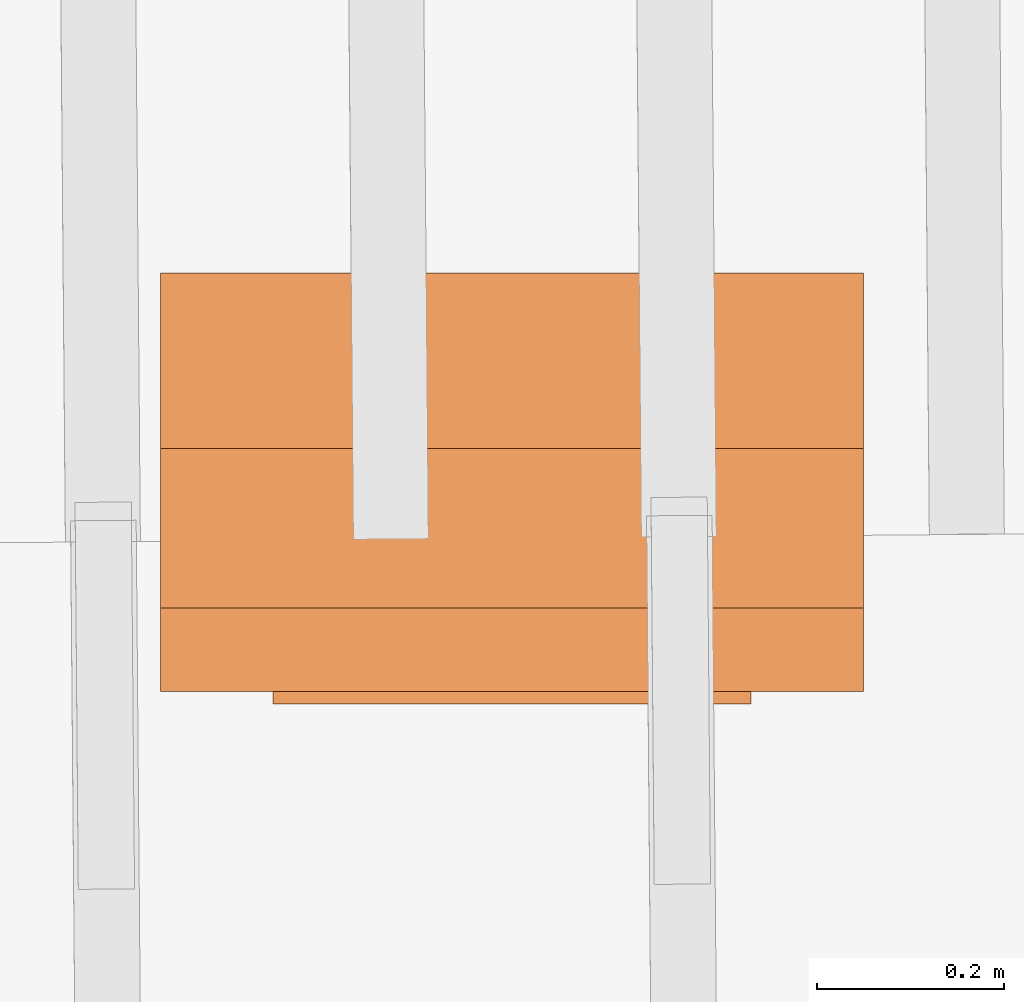
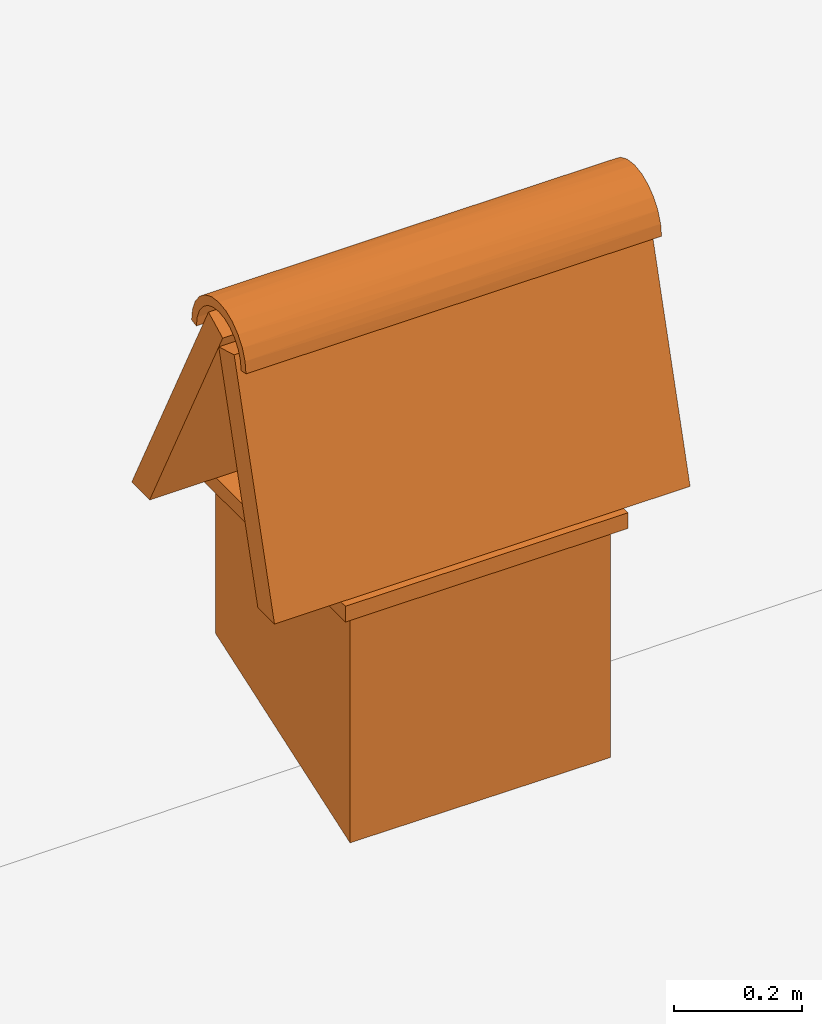
# One storey, part 19 of 19: 1 proxy.
"""IFC4 building model written with IfcOpenShell, lengths in metres."""

from ifc_helpers import new_model, entity, si_unit, converted_unit, derived_unit, direction, frame, origin, place, context, subcontext, project, spatial, polygons, source, transform, mapped, material, type_object, type_shapes, element, save


model = new_model("IFC4")

# Units and contexts
model_context = context("Model", 3, precision=1e-05, world=origin(), true_north=direction((6.123233995736766e-17, 1.0)))
body_context = subcontext(model_context, "Body", "Model", "MODEL_VIEW")
ifc_project = project(units=[si_unit("LENGTHUNIT", "METRE"), si_unit("AREAUNIT", "SQUARE_METRE"), si_unit("VOLUMEUNIT", "CUBIC_METRE"), converted_unit("PLANEANGLEUNIT", "DEGREE", entity("IfcPlaneAngleMeasure", 0.017453292519943278), si_unit("PLANEANGLEUNIT", "RADIAN"), dimensions=[0, 0, 0, 0, 0, 0, 0]), derived_unit("THERMALTRANSMITTANCEUNIT", [(si_unit("MASSUNIT", "GRAM", prefix="KILO"), 1), (si_unit("THERMODYNAMICTEMPERATUREUNIT", "KELVIN"), -1), (si_unit("TIMEUNIT", "SECOND"), -3)])], contexts=[model_context])

# Site, building, storey
site_placement = place(None, origin())
site = spatial("IfcSite", under=ifc_project, at=site_placement, CompositionType="ELEMENT")
building_placement = place(site_placement, origin())
building = spatial("IfcBuilding", under=site, at=building_placement, CompositionType="ELEMENT")
storey_placement = place(building_placement, frame((0.0, 0.0, 3.28)))
storey = spatial("IfcBuildingStorey", under=building, at=storey_placement, Name="Livello Copertura", CompositionType="ELEMENT", Elevation=3.28)

# Proxy
ifc_material = material()
building_element_proxy_type = type_object("IfcBuildingElementProxyType", PredefinedType="NOTDEFINED", material=ifc_material)
shared_shape = source(origin(), body_context, "Body", "Tessellation", [
    polygons([(2.6212307994126216, -3.2371951689083103, 1.053179634513283), (2.6212307994126216, -3.2221951689083106, 1.0505236913281664), (2.6212307994126216, -3.2198099767485453, 1.068641024485343), (2.6212307994126216, -3.212816947173221, 1.0855236913281665), (2.6212307994126216, -3.2016926435913686, 1.1000211660112251), (2.6212307994126216, -3.1871951689083096, 1.111145469593077), (2.6212307994126216, -3.170312502065486, 1.118138499168401), (2.6212307994126216, -3.1521951689083094, 1.1205236913281658), (2.6212307994126216, -3.134077835751133, 1.1181384991684), (2.6212307994126216, -3.1171951689083097, 1.111145469593076), (2.6212307994126216, -3.1026976942252515, 1.1000211660112234), (2.6212307994126216, -3.0915733906433993, 1.0855236913281647), (2.6212307994126216, -3.0845803610680758, 1.0686410244853413), (2.6212307994126216, -3.0821951689083105, 1.0505236913281655), (2.6212307994126216, -3.0671951689083103, 1.0531796345132847), (2.6212307994126216, -3.07009147367374, 1.0751792533469988), (2.6212307994126216, -3.0785830095866333, 1.0956796345132842), (2.6212307994126216, -3.0920910925074545, 1.113283710914141), (2.6212307994126216, -3.109695168908311, 1.1267917938349612), (2.6212307994126216, -3.130195550074597, 1.135283329747855), (2.6212307994126216, -3.152195168908311, 1.1381796345132837), (2.6212307994126216, -3.1741947877420253, 1.1352833297478542), (2.6212307994126216, -3.194695168908311, 1.1267917938349603), (2.6212307994126216, -3.2122992453091674, 1.1132837109141391), (2.6212307994126216, -3.225807328229988, 1.0956796345132824), (2.6212307994126216, -3.2342988641428816, 1.075179253346997), (1.8712307994126212, -3.0821951689083105, 1.0505236913281646), (1.8712307994126212, -3.0845803610680758, 1.0686410244853413), (1.8712307994126212, -3.0915733906433993, 1.0855236913281647), (1.8712307994126212, -3.1026976942252515, 1.1000211660112234), (1.8712307994126212, -3.1171951689083097, 1.111145469593076), (1.8712307994126212, -3.134077835751133, 1.1181384991684), (1.8712307994126212, -3.1521951689083094, 1.1205236913281658), (1.8712307994126212, -3.170312502065486, 1.118138499168401), (1.8712307994126212, -3.1871951689083096, 1.111145469593077), (1.8712307994126212, -3.2016926435913686, 1.1000211660112251), (1.8712307994126212, -3.212816947173221, 1.0855236913281665), (1.8712307994126212, -3.2198099767485453, 1.068641024485343), (1.8712307994126212, -3.2221951689083106, 1.0505236913281664), (1.8712307994126212, -3.2371951689083103, 1.053179634513283), (1.8712307994126212, -3.2342988641428816, 1.075179253346997), (1.8712307994126212, -3.225807328229988, 1.0956796345132824), (1.8712307994126212, -3.2122992453091674, 1.1132837109141391), (1.8712307994126212, -3.194695168908311, 1.1267917938349603), (1.8712307994126212, -3.1741947877420253, 1.1352833297478542), (1.8712307994126212, -3.152195168908311, 1.1381796345132837), (1.8712307994126212, -3.130195550074597, 1.135283329747855), (1.8712307994126212, -3.109695168908311, 1.1267917938349612), (1.8712307994126212, -3.0920910925074545, 1.113283710914141), (1.8712307994126212, -3.0785830095866333, 1.0956796345132842), (1.8712307994126212, -3.07009147367374, 1.0751792533469988), (1.8712307994126212, -3.0671951689083103, 1.0531796345132847), (2.2462307994017965, -3.230724929171603, 1.085707726264718), (2.2462307994026767, -3.219630202832822, 1.1049243559793416), (2.2462307994041453, -3.1847232606590286, 1.1317093947768733), (2.2462307994034547, -3.2039398903737597, 1.1206146684382627), (2.2462307994047594, -3.1632898952467023, 1.137452447730098), (2.1931500444311176, -3.2371951689083103, 1.053179634513283), (2.246230799405804, -3.1196670771570254, 1.1317093947766388), (2.2462307994062507, -3.1004504474423666, 1.1206146684378835), (2.2462307994070216, -3.073665408644765, 1.0857077262641095), (2.246230799406654, -3.08476013498341, 1.1049243559788353), (2.2993115545684883, -3.0671951689083103, 1.0531796345132847), (2.2462307994199904, -3.1411004425683275, 1.1374524477298884), (2.2675139917151523, -3.235591655600428, 1.0696121025997085), (2.2249476069846326, -3.0687986822158146, 1.0696121025977918), (2.163367754497202, -3.0821951689083105, 1.0505236913281655), (2.246230799457387, -3.0875236016352936, 1.0773115316004178), (2.2462307994454767, -3.1095818688819326, 1.1060584251518), (2.2462307994507458, -3.096660435091687, 1.0931369913636804), (2.2462307994412267, -3.1254073286470505, 1.1151952586057359), (2.246230799388416, -3.143058335453642, 1.119924831624429), (2.246230799432456, -3.178983009176854, 1.1151952586027187), (2.2462307994304145, -3.1948084689412237, 1.1060584251467853), (2.2462307994271735, -3.21686673618501, 1.0773115315915254), (2.2462307994286723, -3.2077299027302923, 1.0931369913566975), (2.3290938448070198, -3.2221951689083097, 1.0505236913281673), (2.2462307994348687, -3.1613320023673066, 1.1199248316238597), (2.2922624357611627, -3.083456250732074, 1.0637509785769073), (2.200199162710917, -3.2209340870868455, 1.0637509785649595)], [[[13, 14, 15, 16, 17, 18, 19, 20, 21, 22, 23, 24, 25, 26, 1, 2, 3, 4, 5, 6, 7, 8, 9, 10, 11, 12]], [[37, 38, 39, 40, 41, 42, 43, 44, 45, 46, 47, 48, 49, 50, 51, 52, 27, 28, 29, 30, 31, 32, 33, 34, 35, 36]], [[1, 58, 40, 39, 77, 2]], [[53, 42, 41]], [[51, 66, 52]], [[40, 58, 1, 65]], [[43, 42, 54]], [[55, 45, 44]], [[47, 64, 59]], [[15, 66, 16]], [[43, 56, 44]], [[26, 65, 1]], [[57, 46, 45]], [[65, 53, 41]], [[65, 41, 40]], [[53, 26, 25]], [[42, 53, 54]], [[54, 25, 24]], [[48, 59, 60]], [[55, 23, 22]], [[54, 53, 25]], [[24, 56, 54]], [[45, 55, 57]], [[55, 56, 23]], [[43, 54, 56]], [[57, 55, 22]], [[15, 63, 52, 66]], [[59, 48, 47]], [[62, 18, 17]], [[50, 62, 61]], [[49, 48, 60]], [[61, 51, 50]], [[60, 19, 18]], [[49, 62, 50]], [[61, 17, 16]], [[66, 61, 16]], [[21, 20, 64]], [[59, 64, 20]], [[46, 57, 64]], [[56, 24, 23]], [[26, 53, 65]], [[60, 59, 19]], [[59, 20, 19]], [[62, 60, 18]], [[17, 61, 62]], [[61, 66, 51]], [[57, 22, 21]], [[49, 60, 62]], [[47, 46, 64]], [[57, 21, 64]], [[44, 56, 55]], [[14, 67, 27, 52, 63, 15]], [[68, 79, 13]], [[3, 80, 75]], [[14, 79, 67]], [[12, 68, 13]], [[69, 11, 10]], [[33, 78, 34]], [[3, 2, 77]], [[12, 11, 70]], [[28, 79, 68]], [[71, 10, 9]], [[14, 13, 79]], [[67, 79, 28]], [[70, 68, 12]], [[28, 27, 67]], [[71, 69, 10]], [[29, 68, 70]], [[69, 70, 11]], [[30, 70, 69]], [[69, 71, 31]], [[30, 69, 31]], [[72, 33, 32]], [[28, 68, 29]], [[78, 72, 8]], [[39, 80, 77]], [[73, 7, 6]], [[75, 76, 4]], [[37, 75, 38]], [[5, 74, 6]], [[75, 4, 3]], [[35, 74, 36]], [[76, 74, 5]], [[5, 4, 76]], [[3, 77, 80]], [[39, 38, 80]], [[7, 78, 8]], [[34, 78, 73]], [[72, 71, 9]], [[33, 72, 78]], [[71, 72, 32]], [[35, 73, 74]], [[74, 73, 6]], [[36, 74, 76]], [[76, 75, 37]], [[8, 72, 9]], [[73, 78, 7]], [[31, 71, 32]], [[34, 73, 35]], [[36, 76, 37]], [[80, 38, 75]], [[29, 70, 30]]], closed=True),
    polygons([(2.6212307994126216, -3.15219516890831, 1.0531796345132838), (2.6212307994126216, -3.200236348467355, 1.0670376670783934), (2.6212307994126216, -3.3263049062784327, 0.630000000000007), (2.6212307994126216, -3.2742662173256054, 0.630000000000007), (1.8712307994126212, -3.3263049062784327, 0.630000000000007), (1.8712307994126212, -3.200236348467355, 1.0670376670783934), (1.8712307994126212, -3.15219516890831, 1.0531796345132838), (1.8712307994126212, -3.2742662173256054, 0.630000000000007)], [[[1, 2, 3, 4]], [[5, 6, 7, 8]], [[2, 1, 7, 6]], [[1, 4, 8, 7]], [[4, 3, 5, 8]], [[3, 2, 6, 5]]], closed=True),
    polygons([(2.6212307994126216, -2.9361034406461957, 0.630000000000007), (2.6212307994126216, -2.879961845744243, 0.6300000000000052), (2.6212307994126216, -3.1199618457442604, 1.1000000000000068), (2.6212307994126216, -3.1644921089896503, 1.0772611421725715), (1.8712307994126212, -3.1199618457442604, 1.1000000000000068), (1.8712307994126212, -2.879961845744243, 0.6300000000000052), (1.8712307994126212, -2.9361034406461957, 0.630000000000007), (1.8712307994126212, -3.1644921089896503, 1.0772611421725715)], [[[1, 2, 3, 4]], [[5, 6, 7, 8]], [[2, 1, 7, 6]], [[1, 4, 8, 7]], [[4, 3, 5, 8]], [[3, 2, 6, 5]]], closed=True),
    polygons([(1.9912307994126264, -2.8799618457442393, 0.6300000000000052), (2.501230799412626, -2.8799618457442393, 0.6300000000000052), (2.501230799412626, -2.8799618457442393, 0.6000000000000068), (1.9912307994126264, -2.8799618457442393, 0.6000000000000068), (2.501230799412626, -3.3399618457442393, 0.6000000000000068), (2.501230799412626, -3.3399618457442393, 0.6300000000000052), (1.9912307994126264, -3.3399618457442393, 0.6300000000000052), (1.9912307994126264, -3.3399618457442393, 0.6000000000000068)], [[[1, 2, 3, 4]], [[5, 6, 7, 8]], [[2, 1, 7, 6]], [[1, 4, 8, 7]], [[4, 3, 5, 8]], [[3, 2, 6, 5]]], closed=True),
    polygons([(2.011230799412626, -3.3199618457442446, 0.5999999999999992), (2.4812307994126264, -3.3199618457442446, 0.5999999999999992), (2.4812307994126264, -2.899961845744246, 0.5999999999999992), (2.011230799412626, -2.899961845744246, 0.5999999999999992), (2.431230799412624, -2.949961845744244, 0.5999999999999992), (2.431230799412624, -3.269961845744255, 0.5999999999999992), (2.061230799412627, -3.269961845744255, 0.5999999999999992), (2.061230799412627, -2.949961845744244, 0.5999999999999992), (2.011230799412626, -3.3199618457442455, 0.15962232078990013), (2.4812307994126264, -3.3199618457442455, 0.15793556207409853), (2.011230799412626, -2.899961845744246, 0.3041926055741402), (2.4812307994126264, -2.899961845744246, 0.3025058468583377), (2.431230799412624, -2.949961845744244, 0.2854698437795582), (2.431230799412624, -3.269961845744255, 0.1753304499860251), (2.061230799412627, -2.949961845744244, 0.28679771766221096), (2.061230799412627, -3.269961845744255, 0.1766583238686774)], [[[1, 2, 3, 4], [5, 6, 7, 8]], [[2, 1, 9, 10]], [[1, 4, 11, 9]], [[4, 3, 12, 11]], [[3, 2, 10, 12]], [[6, 5, 13, 14]], [[5, 8, 15, 13]], [[8, 7, 16, 15]], [[7, 6, 14, 16]], [[11, 12, 10, 9], [13, 15, 16, 14]]], closed=True),
])
type_shapes(building_element_proxy_type, [shared_shape])
proxy_placement = place(storey_placement, frame((0.0, 0.0, 0.11999999999999492)))
element("IfcBuildingElementProxy", 1, at=proxy_placement, inside=storey, type_object=building_element_proxy_type, material=ifc_material, PredefinedType="NOTDEFINED", context=body_context, shape_type="MappedRepresentation", body=[
    mapped(shared_shape, transform((0.0, 0.0, 0.0), scale=1.0)),
])

save(model, "model.ifc")
